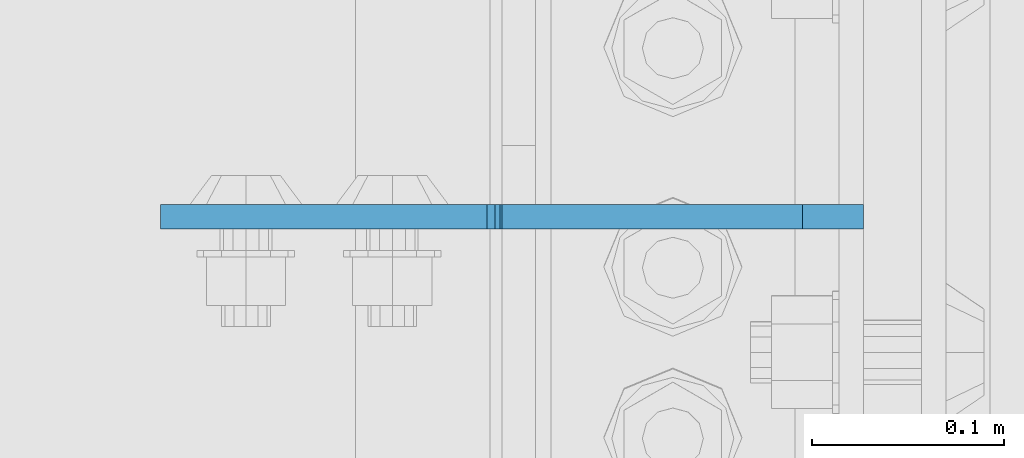
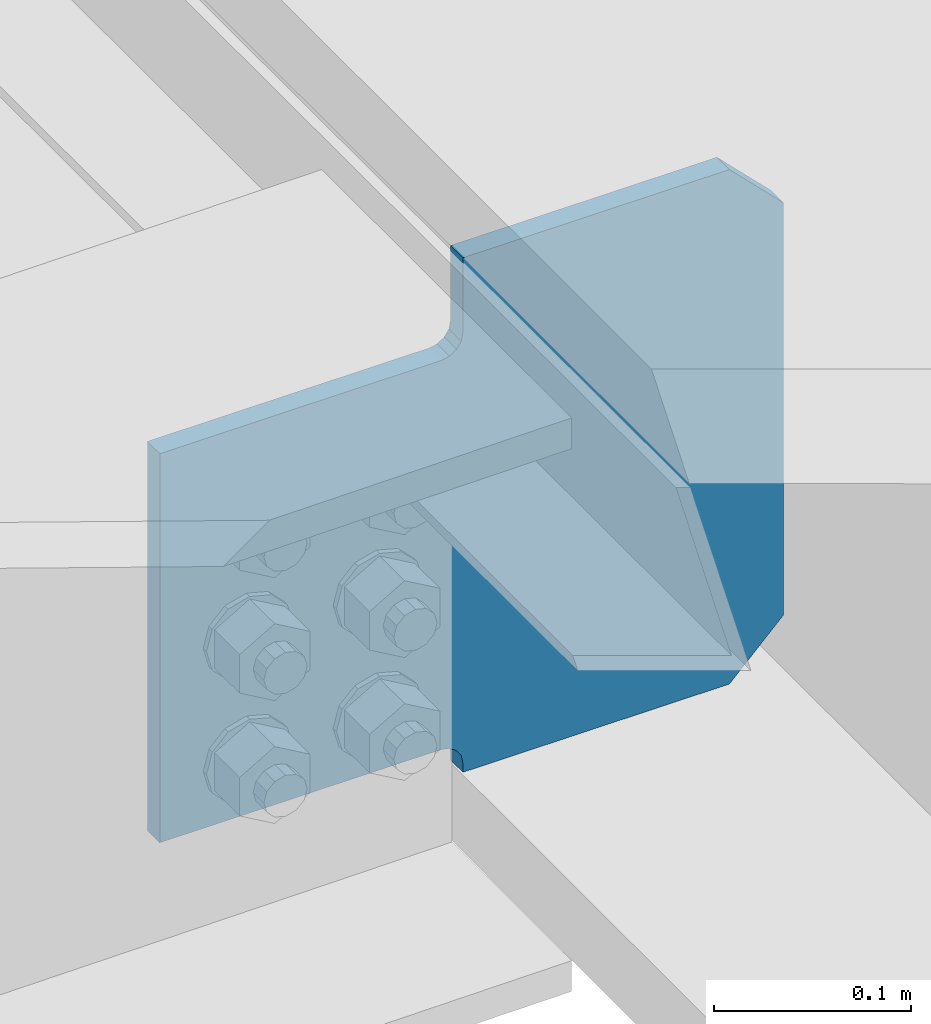
# One storey, part 3598 of 3843: 1 plate, 1 element without a shape of its own.
"""IFC2X3 building model written with IfcOpenShell, lengths in millimetres."""

from ifc_helpers import new_model, si_unit, frame, origin_with_axes, place, context, subcontext, project, spatial, faceted_brep, material, type_object, element, aggregate, save


model = new_model("IFC2X3")

# Units and contexts
model_context = context("Model", 3, precision=1e-05, world=origin_with_axes())
body_context = subcontext(model_context, "Body", "Model", "MODEL_VIEW")
ifc_project = project(units=[si_unit("LENGTHUNIT", "METRE", prefix="MILLI"), si_unit("AREAUNIT", "SQUARE_METRE"), si_unit("VOLUMEUNIT", "CUBIC_METRE"), si_unit("MASSUNIT", "GRAM", prefix="KILO"), si_unit("TIMEUNIT", "SECOND"), si_unit("PLANEANGLEUNIT", "RADIAN"), si_unit("SOLIDANGLEUNIT", "STERADIAN"), si_unit("THERMODYNAMICTEMPERATUREUNIT", "DEGREE_CELSIUS"), si_unit("LUMINOUSINTENSITYUNIT", "LUMEN")], contexts=[model_context])

# Site, building, storey
site_placement = place(None, origin_with_axes())
site = spatial("IfcSite", under=ifc_project, at=site_placement, CompositionType="ELEMENT")
building_placement = place(site_placement, origin_with_axes())
building = spatial("IfcBuilding", under=site, at=building_placement, Name="Undefined", CompositionType="ELEMENT")
storey_placement = place(building_placement, origin_with_axes())
storey = spatial("IfcBuildingStorey", under=building, at=storey_placement, Name="Undefined", CompositionType="ELEMENT", Elevation=0.0)

# Assembly, plate
assembly_placement = place(storey_placement, origin_with_axes())
assembly = element("IfcElementAssembly", 1, at=assembly_placement, inside=storey, Name="BEAM", AssemblyPlace="NOTDEFINED", PredefinedType="RIGID_FRAME")
ifc_material = material(Name="STEEL/A572-50")
plate_type = type_object("IfcPlateType", PredefinedType="NOTDEFINED")
plate_placement = place(assembly_placement, frame((85633.7187500079, 47784.7421901252, 39415.2037744646), z_axis=(-0.707106781186548, 0.0, 0.707106781186548), x_axis=(-0.707106781186548, 0.0, -0.707106781186548)))
plate = element("IfcPlate", 2, at=plate_placement, type_object=plate_type, material=ifc_material, Name="PLATE", context=body_context, shape_type="Brep", body=[
    faceted_brep([(0.0, -6.3499999046162, 0.0), (-180.711367998461, -6.34999999999854, 180.711367998443), (-180.711367998461, 6.34999999999854, 180.711367998443), (7.27595761418343e-12, 6.3499999046162, 0.0), (-180.711367997981, -6.34999999999854, 225.612648604045), (-180.711367997981, 6.34999999999854, 225.612648604045), (-70.1419642730471, -6.34999999999854, 336.182052328979), (-70.1419642730471, 6.34999999999854, 336.182052328979), (-37.235447574014, -6.34999999999854, 303.275535629949), (-37.235447574014, 6.34999999999854, 303.275535629949), (-33.115271105853, -6.34999999999854, 300.52252172949), (-33.115271105853, 6.34999999999854, 300.52252172949), (-28.2551915877993, -6.34999999999854, 299.555791806921), (-28.2551915877993, 6.34999999999854, 299.555791806921), (-23.3951120697457, -6.34999999999854, 300.522521729541), (-23.3951120697457, 6.34999999999854, 300.522521729541), (-19.2749356015702, -6.34999999999854, 303.275535630048), (-19.2749356015702, 6.34999999999854, 303.275535630048), (97.4683938765811, -6.34999999999854, 420.018865108192), (97.4683938765811, 6.34999999999854, 420.018865108192), (268.093260176087, -6.34999999999854, 249.3939988087), (268.093260176087, 6.34999999999854, 249.3939988087), (151.349930697921, -6.34999999999854, 132.650669330556), (151.349930697921, 6.34999999999854, 132.650669330556), (148.596916797425, -6.34999999999854, 128.530492862374), (148.596916797425, 6.34999999999854, 128.530492862374), (147.630186874812, -6.34999999999854, 123.670413344309), (147.630186874812, 6.34999999999854, 123.670413344309), (148.596916797382, -6.34999999999854, 118.810333826255), (148.596916797382, 6.34999999999854, 118.810333826255), (151.349930697834, -6.34999999999854, 114.690157358105), (151.349930697834, 6.34999999999854, 114.690157358105), (155.470684068496, -6.35000000000582, 110.569403464237), (155.470684068496, 6.35000000000582, 110.569403464237), (44.9012806051323, -6.35000000000582, -1.45519152283669e-11), (44.9012806051323, 6.35000000000582, -1.45519152283669e-11)], [[[0, 1, 2, 3]], [[1, 4, 5, 2]], [[4, 6, 7, 5]], [[6, 8, 9, 7]], [[8, 10, 11, 9]], [[10, 12, 13, 11]], [[12, 14, 15, 13]], [[14, 16, 17, 15]], [[16, 18, 19, 17]], [[18, 20, 21, 19]], [[20, 22, 23, 21]], [[22, 24, 25, 23]], [[24, 26, 27, 25]], [[26, 28, 29, 27]], [[28, 30, 31, 29]], [[30, 32, 33, 31]], [[32, 34, 35, 33]], [[34, 0, 3, 35]], [[5, 7, 9, 11, 13, 15, 17, 19, 21, 23, 25, 27, 29, 31, 33, 35, 3, 2]], [[34, 32, 30, 28, 26, 24, 22, 20, 18, 16, 14, 12, 10, 8, 6, 4, 1, 0]]]),
])
aggregate(assembly, [plate])

save(model, "model.ifc")
